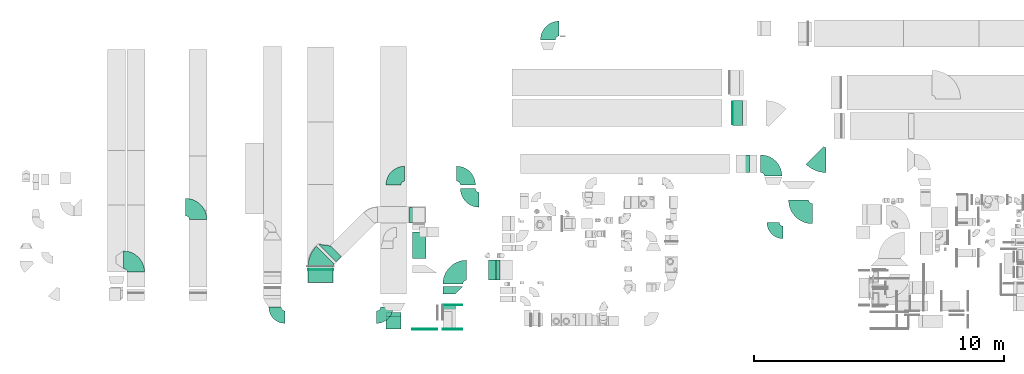
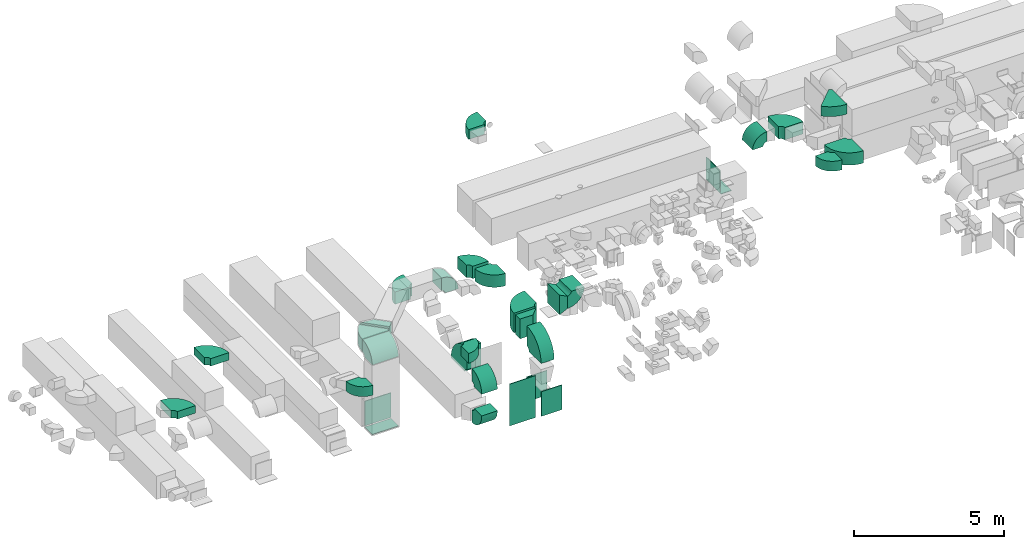
# One storey, part 2 of 59: 32 flow fittings.
"""IFC2X3 building model written with IfcOpenShell, lengths in millimetres."""

from ifc_helpers import new_model, entity, si_unit, converted_unit, derived_unit, direction, frame, frame_2d, origin, origin_2d_with_axis, place, context, subcontext, project, spatial, polyline, circle_curve, parameter, trimmed, segment, composite_curve, rectangle, outline, extrude, source, transform, mapped, material, type_object, type_shapes, element, save


model = new_model("IFC2X3")

# Units and contexts
model_context = context("Model", 3, precision=0.01, world=origin(), true_north=direction((6.12303176911189e-17, 1.0)))
body_context = subcontext(model_context, "Body", "Model", "MODEL_VIEW")
ifc_project = project(units=[si_unit("LENGTHUNIT", "METRE", prefix="MILLI"), si_unit("AREAUNIT", "SQUARE_METRE"), si_unit("VOLUMEUNIT", "CUBIC_METRE"), converted_unit("PLANEANGLEUNIT", "DEGREE", entity("IfcRatioMeasure", 0.0174532925199433), si_unit("PLANEANGLEUNIT", "RADIAN"), dimensions=[0, 0, 0, 0, 0, 0, 0]), si_unit("MASSUNIT", "GRAM", prefix="KILO"), derived_unit("MASSDENSITYUNIT", [(si_unit("MASSUNIT", "GRAM", prefix="KILO"), 1), (si_unit("LENGTHUNIT", "METRE"), -3)]), derived_unit("MOMENTOFINERTIAUNIT", [(si_unit("LENGTHUNIT", "METRE"), 4)]), si_unit("TIMEUNIT", "SECOND"), si_unit("FREQUENCYUNIT", "HERTZ"), si_unit("THERMODYNAMICTEMPERATUREUNIT", "DEGREE_CELSIUS"), derived_unit("THERMALTRANSMITTANCEUNIT", [(si_unit("MASSUNIT", "GRAM", prefix="KILO"), 1), (si_unit("THERMODYNAMICTEMPERATUREUNIT", "KELVIN"), -1), (si_unit("TIMEUNIT", "SECOND"), -3)]), derived_unit("VOLUMETRICFLOWRATEUNIT", [(si_unit("LENGTHUNIT", "METRE"), 3), (si_unit("TIMEUNIT", "SECOND"), -1)]), derived_unit("MASSFLOWRATEUNIT", [(si_unit("MASSUNIT", "GRAM", prefix="KILO"), 1), (si_unit("TIMEUNIT", "SECOND"), -1)]), derived_unit("ROTATIONALFREQUENCYUNIT", [(si_unit("TIMEUNIT", "SECOND"), -1)]), si_unit("ELECTRICCURRENTUNIT", "AMPERE"), si_unit("ELECTRICVOLTAGEUNIT", "VOLT"), si_unit("POWERUNIT", "WATT"), si_unit("FORCEUNIT", "NEWTON", prefix="KILO"), si_unit("ILLUMINANCEUNIT", "LUX"), si_unit("LUMINOUSFLUXUNIT", "LUMEN"), si_unit("LUMINOUSINTENSITYUNIT", "CANDELA"), derived_unit("USERDEFINED", [(si_unit("MASSUNIT", "GRAM", prefix="KILO"), -1), (si_unit("LENGTHUNIT", "METRE"), -2), (si_unit("TIMEUNIT", "SECOND"), 3), (si_unit("LUMINOUSFLUXUNIT", "LUMEN"), 1)]), derived_unit("LINEARVELOCITYUNIT", [(si_unit("LENGTHUNIT", "METRE"), 1), (si_unit("TIMEUNIT", "SECOND"), -1)]), si_unit("PRESSUREUNIT", "PASCAL"), derived_unit("USERDEFINED", [(si_unit("LENGTHUNIT", "METRE"), -2), (si_unit("MASSUNIT", "GRAM", prefix="KILO"), 1), (si_unit("TIMEUNIT", "SECOND"), -2)]), derived_unit("LINEARFORCEUNIT", [(si_unit("MASSUNIT", "GRAM", prefix="KILO"), 1), (si_unit("LENGTHUNIT", "METRE"), 1), (si_unit("TIMEUNIT", "SECOND"), -2), (si_unit("LENGTHUNIT", "METRE"), -1)]), derived_unit("PLANARFORCEUNIT", [(si_unit("MASSUNIT", "GRAM", prefix="KILO"), 1), (si_unit("LENGTHUNIT", "METRE"), 1), (si_unit("TIMEUNIT", "SECOND"), -2), (si_unit("LENGTHUNIT", "METRE"), -2)])], contexts=[model_context])

# Site, building, storey
site_placement = place(None, origin())
site = spatial("IfcSite", under=ifc_project, at=site_placement, CompositionType="ELEMENT")
building_placement = place(site_placement, origin())
building = spatial("IfcBuilding", under=site, at=building_placement, CompositionType="ELEMENT")
storey_placement = place(building_placement, frame((0.0, 0.0, 28200.0)))
storey = spatial("IfcBuildingStorey", under=building, at=storey_placement, CompositionType="ELEMENT", Elevation=28200.0)

# Flow fittings
ifc_material = material()
duct_fitting_type_1 = type_object("IfcDuctFittingType", PredefinedType="NOTDEFINED", material=ifc_material)
shared_shape_1 = source(origin(), body_context, "Body", "SweptSolid", [
    extrude(rectangle(XDim=24.9999999999999, YDim=400.0, at=origin_2d_with_axis()), frame((12.5, 0.0, -500.0)), (0.0, 0.0, 1.0), 1000.0),
])
type_shapes(duct_fitting_type_1, [shared_shape_1])
flow_fitting_1_placement = place(storey_placement, frame((37100.03, 16469.6, 236.05), z_axis=(0.0, -1.0, 0.0), x_axis=(0.0, 0.0, -1.0)))
element("IfcFlowFitting", 1, at=flow_fitting_1_placement, inside=storey, type_object=duct_fitting_type_1, material=ifc_material, context=body_context, shape_type="MappedRepresentation", body=[
    mapped(shared_shape_1, transform((0.0, 0.0, 0.0), scale=1.0)),
])
duct_fitting_type_2 = type_object("IfcDuctFittingType", PredefinedType="NOTDEFINED", material=ifc_material)
shared_shape_2 = source(origin(), body_context, "Body", "SweptSolid", [
    extrude(outline(polyline([(-250.0, -150.0), (250.0, -150.0), (400.0, 150.0), (-400.0, 150.0), (-250.0, -150.0)])), frame((150.0, -400.0, 0.0), z_axis=(0.0, 1.0, 0.0), x_axis=(0.0, 0.0, 1.0)), (0.0, 0.0, 1.0), 800.0),
])
type_shapes(duct_fitting_type_2, [shared_shape_2])
flow_fitting_2_placement = place(storey_placement, frame((27424.64, 10177.84, 2900.0), z_axis=(0.0, 0.0, 1.0), x_axis=(-1.0, 0.0, 0.0)))
element("IfcFlowFitting", 2, at=flow_fitting_2_placement, inside=storey, type_object=duct_fitting_type_2, material=ifc_material, context=body_context, shape_type="MappedRepresentation", body=[
    mapped(shared_shape_2, transform((0.0, 0.0, 0.0), scale=1.0)),
])
duct_fitting_type_3 = type_object("IfcDuctFittingType", PredefinedType="NOTDEFINED", material=ifc_material)
shared_shape_3 = source(origin(), body_context, "Body", "SweptSolid", [
    extrude(outline(polyline([(-150.0, -325.0), (150.0, -325.0), (150.0, 175.0), (-150.0, 475.0), (-150.0, -325.0)])), frame((150.0, -75.0, -400.0)), (0.0, 0.0, 1.0), 800.0),
])
type_shapes(duct_fitting_type_3, [shared_shape_3])
flow_fitting_3_placement = place(storey_placement, frame((25690.29, 9530.98, 2900.0), z_axis=(0.0, 0.0, 1.0), x_axis=(0.0, -1.0, 0.0)))
element("IfcFlowFitting", 3, at=flow_fitting_3_placement, inside=storey, type_object=duct_fitting_type_3, material=ifc_material, context=body_context, shape_type="MappedRepresentation", body=[
    mapped(shared_shape_3, transform((0.0, 0.0, 0.0), scale=1.0)),
])
duct_fitting_type_4 = type_object("IfcDuctFittingType", PredefinedType="NOTDEFINED", material=ifc_material)
shared_shape_4 = source(origin(), body_context, "Body", "SweptSolid", [
    extrude(rectangle(XDim=24.9999999999999, YDim=780.0, at=origin_2d_with_axis()), frame((12.5, 0.0, -500.0)), (0.0, 0.0, 1.0), 1000.0),
])
type_shapes(duct_fitting_type_4, [shared_shape_4])
for number, where, z_axis, x_axis in (
    (4, (25679.29, 7824.6, 725.0), (0.0, 0.0, 1.0), (0.0, -1.0, 0.0)),
    (5, (25679.29, 8774.6, 725.0), (0.0, 0.0, 1.0), (0.0, 1.0, 0.0)),
):
    element("IfcFlowFitting", number, at=place(storey_placement, frame(where, z_axis=z_axis, x_axis=x_axis)), inside=storey, type_object=duct_fitting_type_4, material=ifc_material, context=body_context, shape_type="MappedRepresentation", body=[
        mapped(shared_shape_4, transform((0.0, 0.0, 0.0), scale=1.0)),
    ])
duct_fitting_type_5 = type_object("IfcDuctFittingType", PredefinedType="NOTDEFINED", material=ifc_material)
shared_shape_5 = source(origin(), body_context, "Body", "SweptSolid", [
    extrude(rectangle(XDim=24.9999999999999, YDim=1000.0, at=origin_2d_with_axis()), frame((12.5, 0.0, -850.0)), (0.0, 0.0, 1.0), 1700.0),
])
type_shapes(duct_fitting_type_5, [shared_shape_5])
flow_fitting_4_placement = place(storey_placement, frame((24567.42, 7824.6, 1110.0), z_axis=(0.0, 0.0, 1.0), x_axis=(0.0, -1.0, 0.0)))
element("IfcFlowFitting", 6, at=flow_fitting_4_placement, inside=storey, type_object=duct_fitting_type_5, material=ifc_material, context=body_context, shape_type="MappedRepresentation", body=[
    mapped(shared_shape_5, transform((0.0, 0.0, 0.0), scale=1.0)),
])
duct_fitting_type_6 = type_object("IfcDuctFittingType", PredefinedType="NOTDEFINED", material=ifc_material)
shared_shape_6 = source(origin(), body_context, "Body", "SweptSolid", [
    extrude(rectangle(XDim=26.0976100393656, YDim=900.0, at=origin_2d_with_axis()), frame((6.95, 0.0, -450.0)), (0.0, 0.0, 1.0), 900.0),
])
type_shapes(duct_fitting_type_6, [shared_shape_6])
flow_fitting_5_placement = place(storey_placement, frame((36900.03, 16479.61, 695.0), z_axis=(1.78893263004675e-06, 1.0, 0.0), x_axis=(-1.0, 1.78893262287182e-06, 0.0)))
element("IfcFlowFitting", 7, at=flow_fitting_5_placement, inside=storey, type_object=duct_fitting_type_6, material=ifc_material, context=body_context, shape_type="MappedRepresentation", body=[
    mapped(shared_shape_6, transform((0.0, 0.0, 0.0), scale=1.0)),
])
duct_fitting_type_7 = type_object("IfcDuctFittingType", PredefinedType="NOTDEFINED", material=ifc_material)
shared_shape_7 = source(origin(), body_context, "Body", "SweptSolid", [
    extrude(rectangle(XDim=24.9999999999999, YDim=1000.0, at=origin_2d_with_axis()), frame((12.5, 0.0, -250.0)), (0.0, 0.0, 1.0), 500.0),
])
type_shapes(duct_fitting_type_7, [shared_shape_7])
flow_fitting_6_placement = place(storey_placement, frame((20389.38, 9936.65, 242.0), z_axis=(0.0, 1.0, 0.0), x_axis=(0.0, 0.0, -1.0)))
element("IfcFlowFitting", 8, at=flow_fitting_6_placement, inside=storey, type_object=duct_fitting_type_7, material=ifc_material, context=body_context, shape_type="MappedRepresentation", body=[
    mapped(shared_shape_7, transform((0.0, 0.0, 0.0), scale=1.0)),
])
duct_fitting_type_8 = type_object("IfcDuctFittingType", PredefinedType="NOTDEFINED", material=ifc_material)
shared_shape_8 = source(origin(), body_context, "Body", "SweptSolid", [
    extrude(rectangle(XDim=1000.0, YDim=26.096, at=origin_2d_with_axis()), frame((6.95, 0.0, -500.0), z_axis=(0.0, 0.0, 1.0), x_axis=(0.0, -1.0, 0.0)), (0.0, 0.0, 1.0), 1000.0),
])
type_shapes(duct_fitting_type_8, [shared_shape_8])
flow_fitting_7_placement = place(storey_placement, frame((20389.38, 10186.65, 782.0), z_axis=(1.0, 0.0, 0.0), x_axis=(0.0, 1.0, 0.0)))
element("IfcFlowFitting", 9, at=flow_fitting_7_placement, inside=storey, type_object=duct_fitting_type_8, material=ifc_material, context=body_context, shape_type="MappedRepresentation", body=[
    mapped(shared_shape_8, transform((0.0, 0.0, 0.0), scale=1.0)),
])
duct_fitting_type_9 = type_object("IfcDuctFittingType", PredefinedType="NOTDEFINED", material=ifc_material)
shared_shape_9 = source(origin(), body_context, "Body", "SweptSolid", [
    extrude(outline(polyline([(-150.0, -400.0), (150.0, -400.0), (150.0, 200.0), (-150.0, 600.0), (-150.0, -400.0)])), frame((150.0, -100.0, -250.0)), (0.0, 0.0, 1.0), 500.000000000001),
])
type_shapes(duct_fitting_type_9, [shared_shape_9])
flow_fitting_8_placement = place(storey_placement, frame((20658.08, 10864.24, 3450.0), z_axis=(0.0, 0.0, 1.0), x_axis=(0.707106781186571, 0.707106781186525, 0.0)))
element("IfcFlowFitting", 10, at=flow_fitting_8_placement, inside=storey, type_object=duct_fitting_type_9, material=ifc_material, context=body_context, shape_type="MappedRepresentation", body=[
    mapped(shared_shape_9, transform((0.0, 0.0, 0.0), scale=1.0)),
])
duct_fitting_type_10 = type_object("IfcDuctFittingType", PredefinedType="NOTDEFINED", material=ifc_material)
shared_shape_10 = source(origin(), body_context, "Body", "SweptSolid", [
    extrude(outline(composite_curve([segment(polyline([(-525.0, -225.0), (75.0, -225.0)]), True, "CONTINUOUS"), segment(trimmed(circle_curve(frame_2d((225.0, -225.0), x_axis=(0.0, 1.0)), 150.0), [parameter(0.0)], [parameter(90.0)], True, "PARAMETER"), False, "CONTINUOUS"), segment(polyline([(225.0, -75.0), (225.0, 525.0)]), True, "CONTINUOUS"), segment(trimmed(circle_curve(frame_2d((225.0, -225.0), x_axis=(0.0, 1.0)), 750.0), [parameter(0.0)], [parameter(90.0)], True, "PARAMETER"), True, "CONTINUOUS")], self_intersect=False)), frame((-225.0, 225.0, -200.0), z_axis=(0.0, 0.0, 1.0), x_axis=(-1.0, 0.0, 0.0)), (0.0, 0.0, 1.0), 400.0),
])
type_shapes(duct_fitting_type_10, [shared_shape_10])
flow_fitting_9_placement = place(storey_placement, frame((29499.08, 19854.6, 3250.05), z_axis=(0.0, 0.0, 1.0), x_axis=(-1.0, 0.0, 0.0)))
element("IfcFlowFitting", 11, at=flow_fitting_9_placement, inside=storey, type_object=duct_fitting_type_10, material=ifc_material, context=body_context, shape_type="MappedRepresentation", body=[
    mapped(shared_shape_10, transform((0.0, 0.0, 0.0), scale=1.0)),
])
duct_fitting_type_11 = type_object("IfcDuctFittingType", PredefinedType="NOTDEFINED", material=ifc_material)
shared_shape_11 = source(origin(), body_context, "Body", "SweptSolid", [
    extrude(outline(composite_curve([segment(polyline([(-375.0, -175.0), (25.0, -175.0)]), True, "CONTINUOUS"), segment(trimmed(circle_curve(frame_2d((175.0, -175.0), x_axis=(0.0, 1.0)), 150.0), [parameter(0.0)], [parameter(90.0000000000001)], True, "PARAMETER"), False, "CONTINUOUS"), segment(polyline([(175.0, -25.0), (175.0, 375.0)]), True, "CONTINUOUS"), segment(trimmed(circle_curve(frame_2d((175.0, -175.0), x_axis=(0.0, 1.0)), 550.0), [parameter(0.0)], [parameter(90.0)], True, "PARAMETER"), True, "CONTINUOUS")], self_intersect=False)), frame((-175.0, 175.0, -350.0), z_axis=(0.0, 0.0, 1.0), x_axis=(-1.0, 0.0, 0.0)), (0.0, 0.0, 1.0), 700.0),
])
type_shapes(duct_fitting_type_11, [shared_shape_11])
flow_fitting_10_placement = place(storey_placement, frame((37223.99, 14444.6, 3450.0), z_axis=(0.0, 1.0, 0.0), x_axis=(0.0, 0.0, 1.0)))
element("IfcFlowFitting", 12, at=flow_fitting_10_placement, inside=storey, type_object=duct_fitting_type_11, material=ifc_material, context=body_context, shape_type="MappedRepresentation", body=[
    mapped(shared_shape_11, transform((0.0, 0.0, 0.0), scale=1.0)),
])
duct_fitting_type_12 = type_object("IfcDuctFittingType", PredefinedType="NOTDEFINED", material=ifc_material)
shared_shape_12 = source(origin(), body_context, "Body", "SweptSolid", [
    extrude(outline(composite_curve([segment(polyline([(-595.19, -229.81), (404.81, -229.81)]), True, "CONTINUOUS"), segment(trimmed(circle_curve(frame_2d((554.81, -229.81), x_axis=(-0.707106781186553, 0.707106781186553)), 150.0), [parameter(0.0)], [parameter(45.0)], True, "PARAMETER"), False, "CONTINUOUS"), segment(polyline([(448.74, -123.74), (-258.36, 583.36)]), True, "CONTINUOUS"), segment(trimmed(circle_curve(frame_2d((554.81, -229.81), x_axis=(-0.707106781186553, 0.707106781186553)), 1150.0), [parameter(0.0)], [parameter(45.0)], True, "PARAMETER"), True, "CONTINUOUS")], self_intersect=False)), frame((-39.43, 95.19, -200.0), z_axis=(0.0, 0.0, 1.0), x_axis=(-0.707106781186547, 0.707106781186548, 0.0)), (0.0, 0.0, 1.0), 400.0),
])
type_shapes(duct_fitting_type_12, [shared_shape_12])
flow_fitting_11_placement = place(storey_placement, frame((40375.86, 14589.12, 3500.0), z_axis=(0.0, 0.0, 1.0), x_axis=(0.707106781186544, -0.707106781186551, 0.0)))
element("IfcFlowFitting", 13, at=flow_fitting_11_placement, inside=storey, type_object=duct_fitting_type_12, material=ifc_material, context=body_context, shape_type="MappedRepresentation", body=[
    mapped(shared_shape_12, transform((0.0, 0.0, 0.0), scale=1.0)),
])
duct_fitting_type_13 = type_object("IfcDuctFittingType", PredefinedType="NOTDEFINED", material=ifc_material)
shared_shape_13 = source(origin(), body_context, "Body", "SweptSolid", [
    extrude(outline(composite_curve([segment(polyline([(-450.0, -200.0), (50.0, -200.0)]), True, "CONTINUOUS"), segment(trimmed(circle_curve(frame_2d((200.0, -200.0), x_axis=(0.0, 1.0)), 150.0), [parameter(0.0)], [parameter(90.0000000000001)], True, "PARAMETER"), False, "CONTINUOUS"), segment(polyline([(200.0, -50.0), (200.0, 450.0)]), True, "CONTINUOUS"), segment(trimmed(circle_curve(frame_2d((200.0, -200.0), x_axis=(0.0, 1.0)), 650.0), [parameter(0.0)], [parameter(90.0000000000001)], True, "PARAMETER"), True, "CONTINUOUS")], self_intersect=False)), frame((-200.0, 200.0, -200.0), z_axis=(0.0, 0.0, 1.0), x_axis=(-1.0, 0.0, 0.0)), (0.0, 0.0, 1.0), 400.0),
])
type_shapes(duct_fitting_type_13, [shared_shape_13])
flow_fitting_12_placement = place(storey_placement, frame((38520.03, 11690.3, 3450.0), z_axis=(0.0, 0.0, 1.0), x_axis=(0.0, -1.0, 0.0)))
element("IfcFlowFitting", 14, at=flow_fitting_12_placement, inside=storey, type_object=duct_fitting_type_13, material=ifc_material, context=body_context, shape_type="MappedRepresentation", body=[
    mapped(shared_shape_13, transform((0.0, 0.0, 0.0), scale=1.0)),
])
flow_fitting_13_placement = place(storey_placement, frame((23040.03, 8299.6, 3350.0)))
element("IfcFlowFitting", 15, at=flow_fitting_13_placement, inside=storey, type_object=duct_fitting_type_13, material=ifc_material, context=body_context, shape_type="MappedRepresentation", body=[
    mapped(shared_shape_13, transform((0.0, 0.0, 0.0), scale=1.0)),
])
flow_fitting_14_placement = place(storey_placement, frame((18564.38, 8299.6, 3350.0), z_axis=(0.0, 0.0, 1.0), x_axis=(0.0, -1.0, 0.0)))
element("IfcFlowFitting", 16, at=flow_fitting_14_placement, inside=storey, type_object=duct_fitting_type_13, material=ifc_material, context=body_context, shape_type="MappedRepresentation", body=[
    mapped(shared_shape_13, transform((0.0, 0.0, 0.0), scale=1.0)),
])
duct_fitting_type_14 = type_object("IfcDuctFittingType", PredefinedType="NOTDEFINED", material=ifc_material)
shared_shape_14 = source(origin(), body_context, "Body", "SweptSolid", [
    extrude(outline(composite_curve([segment(polyline([(-600.0, -250.0), (100.0, -250.0)]), True, "CONTINUOUS"), segment(trimmed(circle_curve(frame_2d((250.0, -250.0), x_axis=(0.0, 1.0)), 150.0), [parameter(0.0)], [parameter(90.0000000000001)], True, "PARAMETER"), False, "CONTINUOUS"), segment(polyline([(250.0, -100.0), (250.0, 600.0)]), True, "CONTINUOUS"), segment(trimmed(circle_curve(frame_2d((250.0, -250.0), x_axis=(0.0, 1.0)), 850.0), [parameter(0.0)], [parameter(90.0)], True, "PARAMETER"), True, "CONTINUOUS")], self_intersect=False)), frame((-250.0, 250.0, -250.0), z_axis=(0.0, 0.0, 1.0), x_axis=(-1.0, 0.0, 0.0)), (0.0, 0.0, 1.0), 500.0),
])
type_shapes(duct_fitting_type_14, [shared_shape_14])
flow_fitting_15_placement = place(storey_placement, frame((38520.03, 14444.6, 3450.0), z_axis=(0.0, 0.0, 1.0), x_axis=(0.0, 1.0, 0.0)))
element("IfcFlowFitting", 17, at=flow_fitting_15_placement, inside=storey, type_object=duct_fitting_type_14, material=ifc_material, context=body_context, shape_type="MappedRepresentation", body=[
    mapped(shared_shape_14, transform((0.0, 0.0, 0.0), scale=1.0)),
])
duct_fitting_type_15 = type_object("IfcDuctFittingType", PredefinedType="NOTDEFINED", material=ifc_material)
shared_shape_15 = source(origin(), body_context, "Body", "SweptSolid", [
    extrude(outline(composite_curve([segment(polyline([(-450.0, -200.0), (50.0, -200.0)]), True, "CONTINUOUS"), segment(trimmed(circle_curve(frame_2d((200.0, -200.0), x_axis=(0.0, 1.0)), 150.0), [parameter(0.0)], [parameter(90.0000000000001)], True, "PARAMETER"), False, "CONTINUOUS"), segment(polyline([(200.0, -50.0), (200.0, 450.0)]), True, "CONTINUOUS"), segment(trimmed(circle_curve(frame_2d((200.0, -200.0), x_axis=(0.0, 1.0)), 650.0), [parameter(0.0)], [parameter(90.0000000000001)], True, "PARAMETER"), True, "CONTINUOUS")], self_intersect=False)), frame((-200.0, 200.0, -300.0), z_axis=(0.0, 0.0, 1.0), x_axis=(-1.0, 0.0, 0.0)), (0.0, 0.0, 1.0), 600.0),
])
type_shapes(duct_fitting_type_15, [shared_shape_15])
for number, where, z_axis, x_axis in (
    (18, (23312.03, 8076.61, 2300.0), (-1.0, 0.0, 0.0), (0.0, 0.0, 1.0)),
    (19, (23312.03, 8076.61, 622.0), (1.0, 0.0, 0.0), (0.0, 0.0, -1.0)),
    (20, (24329.3, 12398.31, 3450.0), (0.0, 1.0, 0.0), (1.0, 0.0, 0.0)),
):
    element("IfcFlowFitting", number, at=place(storey_placement, frame(where, z_axis=z_axis, x_axis=x_axis)), inside=storey, type_object=duct_fitting_type_15, material=ifc_material, context=body_context, shape_type="MappedRepresentation", body=[
        mapped(shared_shape_15, transform((0.0, 0.0, 0.0), scale=1.0)),
    ])
duct_fitting_type_16 = type_object("IfcDuctFittingType", PredefinedType="NOTDEFINED", material=ifc_material)
shared_shape_16 = source(origin(), body_context, "Body", "SweptSolid", [
    extrude(outline(composite_curve([segment(polyline([(-675.0, -275.0), (125.0, -275.0)]), True, "CONTINUOUS"), segment(trimmed(circle_curve(frame_2d((275.0, -275.0), x_axis=(0.0, 1.0)), 150.0), [parameter(0.0)], [parameter(90.0000000000001)], True, "PARAMETER"), False, "CONTINUOUS"), segment(polyline([(275.0, -125.0), (275.0, 675.0)]), True, "CONTINUOUS"), segment(trimmed(circle_curve(frame_2d((275.0, -275.0), x_axis=(0.0, 1.0)), 950.0), [parameter(0.0)], [parameter(90.0000000000001)], True, "PARAMETER"), True, "CONTINUOUS")], self_intersect=False)), frame((-275.0, 275.0, -400.0), z_axis=(0.0, 0.0, 1.0), x_axis=(-1.0, 0.0, 0.0)), (0.0, 0.0, 1.0), 800.0),
])
type_shapes(duct_fitting_type_16, [shared_shape_16])
flow_fitting_16_placement = place(storey_placement, frame((25690.29, 10177.84, 2900.0), z_axis=(0.0, 0.0, 1.0), x_axis=(-1.0, 0.0, 0.0)))
element("IfcFlowFitting", 21, at=flow_fitting_16_placement, inside=storey, type_object=duct_fitting_type_16, material=ifc_material, context=body_context, shape_type="MappedRepresentation", body=[
    mapped(shared_shape_16, transform((0.0, 0.0, 0.0), scale=1.0)),
])
duct_fitting_type_17 = type_object("IfcDuctFittingType", PredefinedType="NOTDEFINED", material=ifc_material)
shared_shape_17 = source(origin(), body_context, "Body", "SweptSolid", [
    extrude(outline(composite_curve([segment(polyline([(-450.0, -200.0), (50.0, -200.0)]), True, "CONTINUOUS"), segment(trimmed(circle_curve(frame_2d((200.0, -200.0), x_axis=(0.0, 1.0)), 150.0), [parameter(0.0)], [parameter(90.0000000000001)], True, "PARAMETER"), False, "CONTINUOUS"), segment(polyline([(200.0, -50.0), (200.0, 450.0)]), True, "CONTINUOUS"), segment(trimmed(circle_curve(frame_2d((200.0, -200.0), x_axis=(0.0, 1.0)), 650.0), [parameter(0.0)], [parameter(90.0000000000001)], True, "PARAMETER"), True, "CONTINUOUS")], self_intersect=False)), frame((-200.0, 200.0, -400.0), z_axis=(0.0, 0.0, 1.0), x_axis=(-1.0, 0.0, 0.0)), (0.0, 0.0, 1.0), 800.0),
])
type_shapes(duct_fitting_type_17, [shared_shape_17])
flow_fitting_17_placement = place(storey_placement, frame((27824.64, 10177.84, 2900.0), z_axis=(0.0, 1.0, 0.0), x_axis=(0.0, 0.0, -1.0)))
element("IfcFlowFitting", 22, at=flow_fitting_17_placement, inside=storey, type_object=duct_fitting_type_17, material=ifc_material, context=body_context, shape_type="MappedRepresentation", body=[
    mapped(shared_shape_17, transform((0.0, 0.0, 0.0), scale=1.0)),
])
duct_fitting_type_18 = type_object("IfcDuctFittingType", PredefinedType="NOTDEFINED", material=ifc_material)
shared_shape_18 = source(origin(), body_context, "Body", "SweptSolid", [
    extrude(outline(composite_curve([segment(polyline([(-675.0, -275.0), (125.0, -275.0)]), True, "CONTINUOUS"), segment(trimmed(circle_curve(frame_2d((275.0, -275.0), x_axis=(0.0, 1.0)), 150.0), [parameter(0.0)], [parameter(90.0000000000001)], True, "PARAMETER"), False, "CONTINUOUS"), segment(polyline([(275.0, -125.0), (275.0, 675.0)]), True, "CONTINUOUS"), segment(trimmed(circle_curve(frame_2d((275.0, -275.0), x_axis=(0.0, 1.0)), 950.0), [parameter(0.0)], [parameter(90.0000000000001)], True, "PARAMETER"), True, "CONTINUOUS")], self_intersect=False)), frame((-275.0, 275.0, -250.0), z_axis=(0.0, 0.0, 1.0), x_axis=(-1.0, 0.0, 0.0)), (0.0, 0.0, 1.0), 500.0),
])
type_shapes(duct_fitting_type_18, [shared_shape_18])
for number, where, z_axis, x_axis in (
    (23, (25540.29, 8224.6, 2900.0), (1.0, 0.0, 0.0), (0.0, -1.0, 0.0)),
    (24, (39537.38, 12439.6, 3000.0), (0.0, 0.0, 1.0), (0.0, -1.0, 0.0)),
):
    element("IfcFlowFitting", number, at=place(storey_placement, frame(where, z_axis=z_axis, x_axis=x_axis)), inside=storey, type_object=duct_fitting_type_18, material=ifc_material, context=body_context, shape_type="MappedRepresentation", body=[
        mapped(shared_shape_18, transform((0.0, 0.0, 0.0), scale=1.0)),
    ])
duct_fitting_type_19 = type_object("IfcDuctFittingType", PredefinedType="NOTDEFINED", material=ifc_material)
shared_shape_19 = source(origin(), body_context, "Body", "SweptSolid", [
    extrude(outline(composite_curve([segment(polyline([(-750.0, -300.0), (150.0, -300.0)]), True, "CONTINUOUS"), segment(trimmed(circle_curve(frame_2d((300.0, -300.0), x_axis=(0.0, 1.0)), 150.0), [parameter(0.0)], [parameter(90.0)], True, "PARAMETER"), False, "CONTINUOUS"), segment(polyline([(300.0, -150.0), (300.0, 750.0)]), True, "CONTINUOUS"), segment(trimmed(circle_curve(frame_2d((300.0, -300.0), x_axis=(0.0, 1.0)), 1050.0), [parameter(0.0)], [parameter(90.0)], True, "PARAMETER"), True, "CONTINUOUS")], self_intersect=False)), frame((-300.0, 300.0, -275.0), z_axis=(0.0, 0.0, 1.0), x_axis=(-1.0, 0.0, 0.0)), (0.0, 0.0, 1.0), 550.0),
])
type_shapes(duct_fitting_type_19, [shared_shape_19])
flow_fitting_18_placement = place(storey_placement, frame((24342.42, 11249.36, 1260.0), z_axis=(-1.0, 0.0, -1.06818908470386e-06), x_axis=(0.0, 1.0, 0.0)))
element("IfcFlowFitting", 25, at=flow_fitting_18_placement, inside=storey, type_object=duct_fitting_type_19, material=ifc_material, context=body_context, shape_type="MappedRepresentation", body=[
    mapped(shared_shape_19, transform((0.0, 0.0, 0.0), scale=1.0)),
])
duct_fitting_type_20 = type_object("IfcDuctFittingType", PredefinedType="NOTDEFINED", material=ifc_material)
shared_shape_20 = source(origin(), body_context, "Body", "SweptSolid", [
    extrude(outline(composite_curve([segment(polyline([(-600.0, -250.0), (100.0, -250.0)]), True, "CONTINUOUS"), segment(trimmed(circle_curve(frame_2d((250.0, -250.0), x_axis=(0.0, 1.0)), 150.0), [parameter(0.0)], [parameter(90.0000000000001)], True, "PARAMETER"), False, "CONTINUOUS"), segment(polyline([(250.0, -100.0), (250.0, 600.0)]), True, "CONTINUOUS"), segment(trimmed(circle_curve(frame_2d((250.0, -250.0), x_axis=(0.0, 1.0)), 850.0), [parameter(0.0)], [parameter(90.0)], True, "PARAMETER"), True, "CONTINUOUS")], self_intersect=False)), frame((-250.0, 250.0, -150.0), z_axis=(0.0, 0.0, 1.0), x_axis=(-1.0, 0.0, 0.0)), (0.0, 0.0, 1.0), 300.0),
])
type_shapes(duct_fitting_type_20, [shared_shape_20])
flow_fitting_19_placement = place(storey_placement, frame((15487.92, 12699.6, 3300.0), z_axis=(0.0, 0.0, 1.0), x_axis=(0.0, 1.0, 0.0)))
element("IfcFlowFitting", 26, at=flow_fitting_19_placement, inside=storey, type_object=duct_fitting_type_20, material=ifc_material, context=body_context, shape_type="MappedRepresentation", body=[
    mapped(shared_shape_20, transform((0.0, 0.0, 0.0), scale=1.0)),
])
duct_fitting_type_21 = type_object("IfcDuctFittingType", PredefinedType="NOTDEFINED", material=ifc_material)
shared_shape_21 = source(origin(), body_context, "Body", "SweptSolid", [
    extrude(outline(composite_curve([segment(polyline([(-525.0, -225.0), (75.0, -225.0)]), True, "CONTINUOUS"), segment(trimmed(circle_curve(frame_2d((225.0, -225.0), x_axis=(0.0, 1.0)), 150.0), [parameter(0.0)], [parameter(90.0)], True, "PARAMETER"), False, "CONTINUOUS"), segment(polyline([(225.0, -75.0), (225.0, 525.0)]), True, "CONTINUOUS"), segment(trimmed(circle_curve(frame_2d((225.0, -225.0), x_axis=(0.0, 1.0)), 750.0), [parameter(0.0)], [parameter(90.0)], True, "PARAMETER"), True, "CONTINUOUS")], self_intersect=False)), frame((-225.0, 225.0, -250.0), z_axis=(0.0, 0.0, 1.0), x_axis=(-1.0, 0.0, 0.0)), (0.0, 0.0, 1.0), 500.0),
])
type_shapes(duct_fitting_type_21, [shared_shape_21])
for number, where, z_axis, x_axis in (
    (27, (23312.03, 14042.74, 2300.0), (0.0, 0.0, 1.0), (-1.0, 0.0, 0.0)),
    (28, (26292.03, 14042.74, 2300.0), (0.0, 0.0, 1.0), (0.0, 1.0, 0.0)),
    (29, (26292.03, 12998.57, 2300.0), (0.0, 0.0, 1.0), (0.0, -1.0, 0.0)),
):
    element("IfcFlowFitting", number, at=place(storey_placement, frame(where, z_axis=z_axis, x_axis=x_axis)), inside=storey, type_object=duct_fitting_type_21, material=ifc_material, context=body_context, shape_type="MappedRepresentation", body=[
        mapped(shared_shape_21, transform((0.0, 0.0, 0.0), scale=1.0)),
    ])
duct_fitting_type_22 = type_object("IfcDuctFittingType", PredefinedType="NOTDEFINED", material=ifc_material)
shared_shape_22 = source(origin(), body_context, "Body", "SweptSolid", [
    extrude(outline(composite_curve([segment(polyline([(-600.0, -250.0), (100.0, -250.0)]), True, "CONTINUOUS"), segment(trimmed(circle_curve(frame_2d((250.0, -250.0), x_axis=(-1.65632627613377e-08, 1.0)), 150.0), [parameter(0.0)], [parameter(89.9999990509946)], True, "PARAMETER"), False, "CONTINUOUS"), segment(polyline([(250.0, -100.0), (250.0, 600.0)]), True, "CONTINUOUS"), segment(trimmed(circle_curve(frame_2d((250.0, -250.0), x_axis=(-1.65632627613377e-08, 1.0)), 850.0), [parameter(0.0)], [parameter(89.9999990509946)], True, "PARAMETER"), True, "CONTINUOUS")], self_intersect=False)), frame((-250.0, 250.0, -150.0), z_axis=(0.0, 0.0, 1.0), x_axis=(-1.0, 1.65632699205633e-08, 0.0)), (0.0, 0.0, 1.0), 300.0),
])
type_shapes(duct_fitting_type_22, [shared_shape_22])
flow_fitting_20_placement = place(storey_placement, frame((12992.68, 10596.44, 3300.0), z_axis=(0.0, 0.0, 1.0), x_axis=(-1.65632699101191e-08, 1.0, 0.0)))
element("IfcFlowFitting", 30, at=flow_fitting_20_placement, inside=storey, type_object=duct_fitting_type_22, material=ifc_material, context=body_context, shape_type="MappedRepresentation", body=[
    mapped(shared_shape_22, transform((0.0, 0.0, 0.0), scale=1.0)),
])
duct_fitting_type_23 = type_object("IfcDuctFittingType", PredefinedType="NOTDEFINED", material=ifc_material)
shared_shape_23 = source(origin(), body_context, "Body", "SweptSolid", [
    extrude(outline(composite_curve([segment(polyline([(-450.0, -200.0), (50.0, -200.0)]), True, "CONTINUOUS"), segment(trimmed(circle_curve(frame_2d((200.0, -200.0), x_axis=(0.0, 1.0)), 150.0), [parameter(0.0)], [parameter(90.0000000000001)], True, "PARAMETER"), False, "CONTINUOUS"), segment(polyline([(200.0, -50.0), (200.0, 450.0)]), True, "CONTINUOUS"), segment(trimmed(circle_curve(frame_2d((200.0, -200.0), x_axis=(0.0, 1.0)), 650.0), [parameter(0.0)], [parameter(90.0000000000001)], True, "PARAMETER"), True, "CONTINUOUS")], self_intersect=False)), frame((-200.0, 200.0, -500.0), z_axis=(0.0, 0.0, 1.0), x_axis=(-1.0, 0.0, 0.0)), (0.0, 0.0, 1.0), 1000.0),
])
type_shapes(duct_fitting_type_23, [shared_shape_23])
flow_fitting_21_placement = place(storey_placement, frame((20389.38, 9936.65, 3450.0), z_axis=(-1.0, 0.0, 0.0), x_axis=(0.0, 0.0, 1.0)))
element("IfcFlowFitting", 31, at=flow_fitting_21_placement, inside=storey, type_object=duct_fitting_type_23, material=ifc_material, context=body_context, shape_type="MappedRepresentation", body=[
    mapped(shared_shape_23, transform((0.0, 0.0, 0.0), scale=1.0)),
])
duct_fitting_type_24 = type_object("IfcDuctFittingType", PredefinedType="NOTDEFINED", material=ifc_material)
shared_shape_24 = source(origin(), body_context, "Body", "SweptSolid", [
    extrude(outline(composite_curve([segment(polyline([(-595.19, -229.81), (404.81, -229.81)]), True, "CONTINUOUS"), segment(trimmed(circle_curve(frame_2d((554.81, -229.81), x_axis=(-0.707106781186553, 0.707106781186553)), 150.0), [parameter(0.0)], [parameter(45.0)], True, "PARAMETER"), False, "CONTINUOUS"), segment(polyline([(448.74, -123.74), (-258.36, 583.36)]), True, "CONTINUOUS"), segment(trimmed(circle_curve(frame_2d((554.81, -229.81), x_axis=(-0.707106781186553, 0.707106781186553)), 1150.0), [parameter(0.0)], [parameter(45.0)], True, "PARAMETER"), True, "CONTINUOUS")], self_intersect=False)), frame((-39.43, 95.19, -250.0), z_axis=(0.0, 0.0, 1.0), x_axis=(-0.707106781186547, 0.707106781186548, 0.0)), (0.0, 0.0, 1.0), 500.0),
])
type_shapes(duct_fitting_type_24, [shared_shape_24])
flow_fitting_22_placement = place(storey_placement, frame((20389.38, 10595.54, 3450.0), z_axis=(-1.51091211771006e-08, 0.0, 1.0), x_axis=(-0.707106781186528, -0.707106781186567, -1.06837620420968e-08)))
element("IfcFlowFitting", 32, at=flow_fitting_22_placement, inside=storey, type_object=duct_fitting_type_24, material=ifc_material, context=body_context, shape_type="MappedRepresentation", body=[
    mapped(shared_shape_24, transform((0.0, 0.0, 0.0), scale=1.0)),
])

save(model, "model.ifc")
